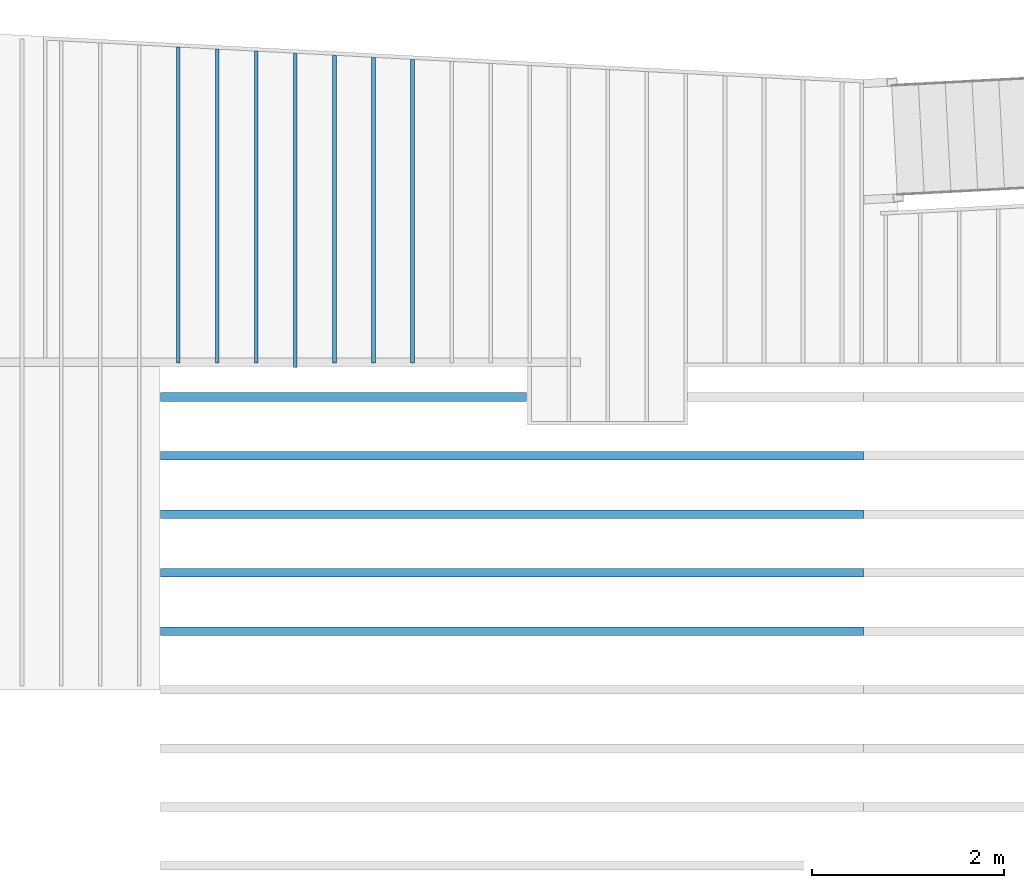
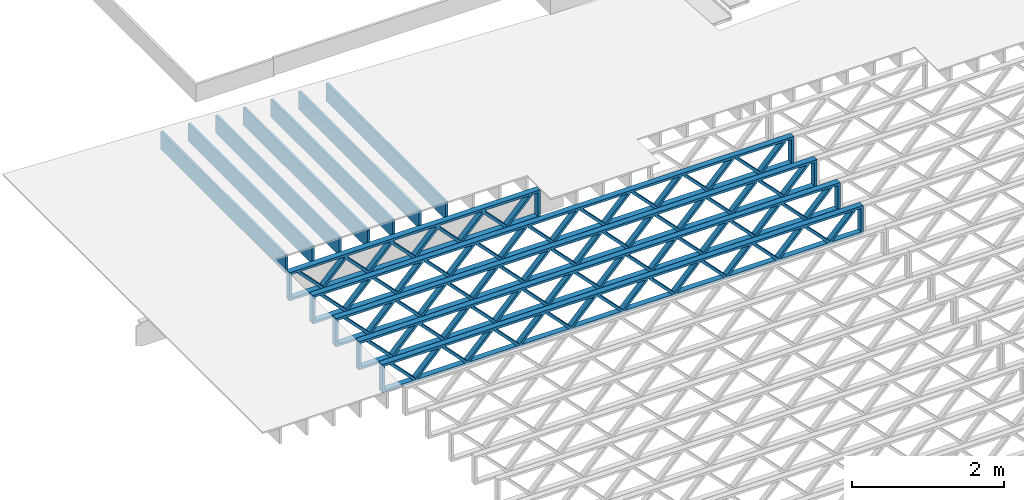
# One storey, part 3 of 23: 12 beams, 2 elements without a shape of their own.
"""IFC4 building model written with IfcOpenShell, lengths in feet."""

from ifc_helpers import new_model, entity, si_unit, converted_unit, derived_unit, direction, frame, frame_2d, origin, origin_2d_with_axis, place, context, subcontext, project, spatial, rectangle, extrude, source, transform, mapped, material, material_profile, profile_set, profile_usage, type_object, type_shapes, element, aggregate, save


model = new_model("IFC4")

# Units and contexts
model_context = context("Model", 3, precision=0.0001, world=origin(), true_north=direction((6.12303176911189e-17, 1.0)))
body_context = subcontext(model_context, "Body", "Model", "MODEL_VIEW")
ifc_project = project(units=[converted_unit("LENGTHUNIT", "FOOT", entity("IfcRatioMeasure", 0.3048), si_unit("LENGTHUNIT", "METRE"), dimensions=[1, 0, 0, 0, 0, 0, 0]), converted_unit("AREAUNIT", "SQUARE FOOT", entity("IfcRatioMeasure", 0.09290304), si_unit("AREAUNIT", "SQUARE_METRE"), dimensions=[2, 0, 0, 0, 0, 0, 0]), converted_unit("VOLUMEUNIT", "CUBIC FOOT", entity("IfcRatioMeasure", 0.028316846592), si_unit("VOLUMEUNIT", "CUBIC_METRE"), dimensions=[3, 0, 0, 0, 0, 0, 0]), converted_unit("PLANEANGLEUNIT", "DEGREE", entity("IfcRatioMeasure", 0.0174532925199433), si_unit("PLANEANGLEUNIT", "RADIAN"), dimensions=[0, 0, 0, 0, 0, 0, 0]), si_unit("MASSUNIT", "GRAM", prefix="KILO"), derived_unit("MASSDENSITYUNIT", [(si_unit("MASSUNIT", "GRAM", prefix="KILO"), 1), (si_unit("LENGTHUNIT", "METRE"), -3)]), derived_unit("MOMENTOFINERTIAUNIT", [(si_unit("LENGTHUNIT", "METRE"), 4)]), si_unit("TIMEUNIT", "SECOND"), si_unit("FREQUENCYUNIT", "HERTZ"), si_unit("THERMODYNAMICTEMPERATUREUNIT", "DEGREE_CELSIUS"), derived_unit("THERMALTRANSMITTANCEUNIT", [(si_unit("MASSUNIT", "GRAM", prefix="KILO"), 1), (si_unit("THERMODYNAMICTEMPERATUREUNIT", "KELVIN"), -1), (si_unit("TIMEUNIT", "SECOND"), -3)]), derived_unit("VOLUMETRICFLOWRATEUNIT", [(si_unit("LENGTHUNIT", "METRE"), 3), (si_unit("TIMEUNIT", "SECOND"), -1)]), si_unit("ELECTRICCURRENTUNIT", "AMPERE"), si_unit("ELECTRICVOLTAGEUNIT", "VOLT"), si_unit("POWERUNIT", "WATT"), si_unit("FORCEUNIT", "NEWTON"), si_unit("ILLUMINANCEUNIT", "LUX"), si_unit("LUMINOUSFLUXUNIT", "LUMEN"), si_unit("LUMINOUSINTENSITYUNIT", "CANDELA"), derived_unit("USERDEFINED", [(si_unit("MASSUNIT", "GRAM", prefix="KILO"), -1), (si_unit("LENGTHUNIT", "METRE"), -2), (si_unit("TIMEUNIT", "SECOND"), 3), (si_unit("LUMINOUSFLUXUNIT", "LUMEN"), 1)]), derived_unit("LINEARVELOCITYUNIT", [(si_unit("LENGTHUNIT", "METRE"), 1), (si_unit("TIMEUNIT", "SECOND"), -1)]), si_unit("PRESSUREUNIT", "PASCAL"), derived_unit("USERDEFINED", [(si_unit("LENGTHUNIT", "METRE"), -2), (si_unit("MASSUNIT", "GRAM", prefix="KILO"), 1), (si_unit("TIMEUNIT", "SECOND"), -2)]), derived_unit("LINEARFORCEUNIT", [(si_unit("MASSUNIT", "GRAM", prefix="KILO"), 1), (si_unit("LENGTHUNIT", "METRE"), 1), (si_unit("TIMEUNIT", "SECOND"), -2), (si_unit("LENGTHUNIT", "METRE"), -1)]), derived_unit("PLANARFORCEUNIT", [(si_unit("MASSUNIT", "GRAM", prefix="KILO"), 1), (si_unit("LENGTHUNIT", "METRE"), 1), (si_unit("TIMEUNIT", "SECOND"), -2), (si_unit("LENGTHUNIT", "METRE"), -2)])], contexts=[model_context])

# Site, building, storey
site_placement = place(None, origin())
site = spatial("IfcSite", under=ifc_project, at=site_placement, CompositionType="ELEMENT")
building_placement = place(site_placement, origin())
building = spatial("IfcBuilding", under=site, at=building_placement, CompositionType="ELEMENT")
storey_placement = place(building_placement, frame((0.0, 0.0, 10.8020833333333)))
storey = spatial("IfcBuildingStorey", under=building, at=storey_placement, Name="2ND FLOOR", CompositionType="ELEMENT", Elevation=10.8020833333333)

# Assembly, beams
assembly_1_placement = place(storey_placement, origin())
assembly_1 = element("IfcElementAssembly", 1, at=assembly_1_placement, inside=storey, Name="Structural Beam System:Structural Framing System", ObjectType="Structural Beam System:Structural Framing System", AssemblyPlace="NOTDEFINED", PredefinedType="BEAM_GRID")
ifc_material_1 = material(Name="WOOD TRUSS", Category="Materials")
ifc_material_profile_1 = material_profile(ifc_material_1, rectangle(XDim=1.73473973950632, YDim=0.125, at=frame_2d((-1.11022302462516e-16, 8.32667268468867e-17), x_axis=(1.0, 0.0))))
ifc_material_profile_2 = material_profile(ifc_material_1, rectangle(XDim=1.73473973950633, YDim=0.125, at=frame_2d((-1.11022302462516e-16, 8.32667268468867e-17), x_axis=(1.0, 0.0))))
ifc_material_profile_3 = material_profile(ifc_material_1, rectangle(XDim=1.73473973950632, YDim=0.125, at=frame_2d((-5.55111512312578e-17, 1.38777878078145e-16), x_axis=(1.0, 0.0))))
ifc_material_profile_4 = material_profile(ifc_material_1, rectangle(XDim=1.73473973950633, YDim=0.125, at=frame_2d((-1.11022302462516e-16, 8.32667268468867e-17), x_axis=(1.0, 0.0))))
ifc_material_profile_5 = material_profile(ifc_material_1, rectangle(XDim=1.73473973950632, YDim=0.125, at=frame_2d((-1.11022302462516e-16, 8.32667268468867e-17), x_axis=(1.0, 0.0))))
ifc_material_profile_6 = material_profile(ifc_material_1, rectangle(XDim=1.73473973950633, YDim=0.125, at=frame_2d((-2.77555756156289e-16, 3.05311331771918e-16), x_axis=(1.0, 0.0))))
ifc_material_profile_7 = material_profile(ifc_material_1, rectangle(XDim=1.73473973950632, YDim=0.124999999999999, at=frame_2d((-3.88578058618805e-16, -2.4980018054066e-16), x_axis=(1.0, 0.0))))
ifc_material_profile_8 = material_profile(ifc_material_1, rectangle(XDim=1.73473973950633, YDim=0.125, at=frame_2d((2.77555756156289e-16, -3.05311331771918e-16), x_axis=(1.0, 0.0))))
ifc_material_profile_9 = material_profile(ifc_material_1, rectangle(XDim=1.73473973950632, YDim=0.124999999999999, at=frame_2d((-1.11022302462516e-16, 8.32667268468867e-17), x_axis=(1.0, 0.0))))
ifc_material_profile_10 = material_profile(ifc_material_1, rectangle(XDim=1.73473973950633, YDim=0.125, at=origin_2d_with_axis()))
ifc_material_profile_11 = material_profile(ifc_material_1, rectangle(XDim=0.124999999999982, YDim=0.291666666666668, at=origin_2d_with_axis()))
ifc_material_profile_12 = material_profile(ifc_material_1, rectangle(XDim=0.124999999999932, YDim=0.291666666666664, at=origin_2d_with_axis()))
ifc_material_profile_13 = material_profile(ifc_material_1, rectangle(XDim=1.25000000000002, YDim=0.29166666666667, at=origin_2d_with_axis()))
ifc_material_profile_14 = material_profile(ifc_material_1, rectangle(XDim=1.25000000000004, YDim=0.291666666666667, at=origin_2d_with_axis()))
ifc_profile_set_1 = profile_set([ifc_material_profile_1, ifc_material_profile_2, ifc_material_profile_3, ifc_material_profile_4, ifc_material_profile_5, ifc_material_profile_6, ifc_material_profile_7, ifc_material_profile_8, ifc_material_profile_9, ifc_material_profile_10, ifc_material_profile_11, ifc_material_profile_12, ifc_material_profile_13, ifc_material_profile_14])
ifc_profile_usage_1 = profile_usage(ifc_profile_set_1, cardinal=8)
beam_type_1 = type_object("IfcBeamType", PredefinedType="BEAM", material=ifc_profile_set_1)
shared_shape_1 = source(origin(), body_context, "Body", "SweptSolid", [
    extrude(rectangle(XDim=1.73473973950632, YDim=0.125, at=frame_2d((-1.11022302462516e-16, 8.32667268468867e-17), x_axis=(1.0, 0.0))), frame((2.91681155651982, -0.145833333333334, 0.0), z_axis=(0.0, 1.0, 0.0), x_axis=(0.693383046997606, 0.0, 0.720569184836762)), (0.0, 0.0, 1.0), 0.291666666666667),
    extrude(rectangle(XDim=1.73473973950633, YDim=0.125, at=frame_2d((-1.11022302462516e-16, 8.32667268468867e-17), x_axis=(1.0, 0.0))), frame((1.66652568284655, -0.145833333333334, 0.0), z_axis=(0.0, 1.0, 0.0), x_axis=(0.69338304699761, 0.0, -0.720569184836758)), (0.0, 0.0, 1.0), 0.291666666666667),
    extrude(rectangle(XDim=1.73473973950632, YDim=0.125, at=frame_2d((-5.55111512312578e-17, 1.38777878078145e-16), x_axis=(1.0, 0.0))), frame((0.625142936836964, -0.145833333333334, 0.0), z_axis=(0.0, 1.0, 0.0), x_axis=(0.693383046997606, 0.0, 0.720569184836762)), (0.0, 0.0, 1.0), 0.291666666666667),
    extrude(rectangle(XDim=1.73473973950633, YDim=0.125, at=frame_2d((-1.11022302462516e-16, 8.32667268468867e-17), x_axis=(1.0, 0.0))), frame((-0.625142936836307, -0.145833333333334, 0.0), z_axis=(0.0, 1.0, 0.0), x_axis=(0.69338304699761, 0.0, -0.720569184836758)), (0.0, 0.0, 1.0), 0.291666666666667),
    extrude(rectangle(XDim=1.73473973950632, YDim=0.125, at=frame_2d((-1.11022302462516e-16, 8.32667268468867e-17), x_axis=(1.0, 0.0))), frame((-1.66652568284589, -0.145833333333334, 0.0), z_axis=(0.0, 1.0, 0.0), x_axis=(0.693383046997606, 0.0, 0.720569184836762)), (0.0, 0.0, 1.0), 0.291666666666667),
    extrude(rectangle(XDim=1.73473973950633, YDim=0.125, at=frame_2d((-2.77555756156289e-16, 3.05311331771918e-16), x_axis=(1.0, 0.0))), frame((-2.91681155651916, -0.145833333333334, 0.0), z_axis=(0.0, 1.0, 0.0), x_axis=(0.69338304699761, 0.0, -0.720569184836758)), (0.0, 0.0, 1.0), 0.291666666666667),
    extrude(rectangle(XDim=1.73473973950632, YDim=0.124999999999999, at=frame_2d((-3.88578058618805e-16, -2.4980018054066e-16), x_axis=(1.0, 0.0))), frame((5.20848017620267, -0.145833333333334, 0.0), z_axis=(0.0, 1.0, 0.0), x_axis=(0.693383046997607, 0.0, 0.720569184836761)), (0.0, 0.0, 1.0), 0.291666666666666),
    extrude(rectangle(XDim=1.73473973950633, YDim=0.125, at=frame_2d((2.77555756156289e-16, -3.05311331771918e-16), x_axis=(1.0, 0.0))), frame((3.9581943025294, -0.145833333333334, 0.0), z_axis=(0.0, 1.0, 0.0), x_axis=(0.69338304699761, 0.0, -0.720569184836758)), (0.0, 0.0, 1.0), 0.291666666666666),
    extrude(rectangle(XDim=1.73473973950632, YDim=0.124999999999999, at=frame_2d((-1.11022302462516e-16, 8.32667268468867e-17), x_axis=(1.0, 0.0))), frame((-3.95819430252874, -0.145833333333334, 0.0), z_axis=(0.0, 1.0, 0.0), x_axis=(0.693383046997606, 0.0, 0.720569184836762)), (0.0, 0.0, 1.0), 0.291666666666667),
    extrude(rectangle(XDim=1.73473973950633, YDim=0.125, at=origin_2d_with_axis()), frame((-5.20848017620202, -0.145833333333334, 0.0), z_axis=(0.0, 1.0, 0.0), x_axis=(0.69338304699761, 0.0, -0.720569184836758)), (0.0, 0.0, 1.0), 0.291666666666666),
    extrude(rectangle(XDim=0.124999999999982, YDim=0.291666666666668, at=origin_2d_with_axis()), frame((-6.25000390603229, 0.0, 0.687500000000054), z_axis=(1.0, 0.0, 0.0), x_axis=(0.0, 0.0, -1.0)), (0.0, 0.0, 1.0), 12.5000078120646),
    extrude(rectangle(XDim=0.124999999999932, YDim=0.291666666666664, at=origin_2d_with_axis()), frame((-6.25000390603208, 0.0, -0.687499999999984), z_axis=(1.0, 0.0, 0.0), x_axis=(0.0, 0.0, -1.0)), (0.0, 0.0, 1.0), 12.5000078120644),
    extrude(rectangle(XDim=1.25000000000002, YDim=0.29166666666667, at=origin_2d_with_axis()), frame((6.12500390603227, 0.0, 0.0), z_axis=(1.0, 0.0, 0.0), x_axis=(0.0, 0.0, -1.0)), (0.0, 0.0, 1.0), 0.12500000000002),
    extrude(rectangle(XDim=1.25000000000004, YDim=0.291666666666667, at=origin_2d_with_axis()), frame((-6.25000390603229, 0.0, 0.0), z_axis=(1.0, 0.0, 0.0), x_axis=(0.0, 0.0, -1.0)), (0.0, 0.0, 1.0), 0.125000000000023),
])
type_shapes(beam_type_1, [shared_shape_1])
beam_1_placement = place(assembly_1_placement, frame((-259.488164391561, 957.861934882651, -0.947916666657857)))
beam_1 = element("IfcBeam", 2, at=beam_1_placement, type_object=beam_type_1, material=ifc_profile_usage_1, PredefinedType="BEAM", context=body_context, shape_type="MappedRepresentation", body=[
    mapped(shared_shape_1, transform((0.0, 0.0, 0.0), scale=1.0)),
])
ifc_profile_usage_2 = profile_usage(ifc_profile_set_1, cardinal=8)
beam_type_2 = type_object("IfcBeamType", PredefinedType="BEAM", material=ifc_profile_set_1)
shared_shape_2 = source(origin(), body_context, "Body", "SweptSolid", [
    extrude(rectangle(XDim=1.73473973950632, YDim=0.124999999999999, at=frame_2d((5.55111512312578e-16, 7.21644966006352e-16), x_axis=(1.0, 0.0))), frame((8.37514585578398, -0.145833333333334, 0.0), z_axis=(0.0, 1.0, 0.0), x_axis=(0.693383046997606, 0.0, 0.720569184836762)), (0.0, 0.0, 1.0), 0.291666666666667),
    extrude(rectangle(XDim=1.73473973950633, YDim=0.125, at=origin_2d_with_axis()), frame((7.12485998211071, -0.145833333333334, 0.0), z_axis=(0.0, 1.0, 0.0), x_axis=(0.69338304699761, 0.0, -0.720569184836758)), (0.0, 0.0, 1.0), 0.291666666666666),
    extrude(rectangle(XDim=1.73473973950632, YDim=0.124999999999999, at=frame_2d((-1.11022302462516e-16, 8.32667268468867e-17), x_axis=(1.0, 0.0))), frame((5.79181154946831, -0.145833333333334, 0.0), z_axis=(0.0, 1.0, 0.0), x_axis=(0.693383046997606, 0.0, 0.720569184836762)), (0.0, 0.0, 1.0), 0.291666666666667),
    extrude(rectangle(XDim=1.73473973950633, YDim=0.125, at=origin_2d_with_axis()), frame((4.54152567579504, -0.145833333333334, 0.0), z_axis=(0.0, 1.0, 0.0), x_axis=(0.69338304699761, 0.0, -0.720569184836758)), (0.0, 0.0, 1.0), 0.291666666666666),
    extrude(rectangle(XDim=1.73473973950632, YDim=0.125, at=frame_2d((2.22044604925031e-16, 3.88578058618805e-16), x_axis=(1.0, 0.0))), frame((3.20847724315264, -0.145833333333334, 0.0), z_axis=(0.0, 1.0, 0.0), x_axis=(0.693383046997606, 0.0, 0.720569184836762)), (0.0, 0.0, 1.0), 0.291666666666667),
    extrude(rectangle(XDim=1.73473973950633, YDim=0.125, at=frame_2d((-1.11022302462516e-16, 8.32667268468867e-17), x_axis=(1.0, 0.0))), frame((1.95819136947937, -0.145833333333334, 0.0), z_axis=(0.0, 1.0, 0.0), x_axis=(0.69338304699761, 0.0, -0.720569184836758)), (0.0, 0.0, 1.0), 0.291666666666667),
    extrude(rectangle(XDim=1.73473973950632, YDim=0.125, at=frame_2d((-5.55111512312578e-17, 1.38777878078145e-16), x_axis=(1.0, 0.0))), frame((0.625142936836964, -0.145833333333334, 0.0), z_axis=(0.0, 1.0, 0.0), x_axis=(0.693383046997606, 0.0, 0.720569184836762)), (0.0, 0.0, 1.0), 0.291666666666667),
    extrude(rectangle(XDim=1.73473973950633, YDim=0.125, at=frame_2d((-1.11022302462516e-16, 8.32667268468867e-17), x_axis=(1.0, 0.0))), frame((-0.625142936836306, -0.145833333333334, 0.0), z_axis=(0.0, 1.0, 0.0), x_axis=(0.69338304699761, 0.0, -0.720569184836758)), (0.0, 0.0, 1.0), 0.291666666666667),
    extrude(rectangle(XDim=1.73473973950632, YDim=0.125, at=frame_2d((-1.11022302462516e-16, 8.32667268468867e-17), x_axis=(1.0, 0.0))), frame((-1.95819136947871, -0.145833333333334, 0.0), z_axis=(0.0, 1.0, 0.0), x_axis=(0.693383046997606, 0.0, 0.720569184836762)), (0.0, 0.0, 1.0), 0.291666666666667),
    extrude(rectangle(XDim=1.73473973950633, YDim=0.125, at=origin_2d_with_axis()), frame((-3.20847724315198, -0.145833333333334, 0.0), z_axis=(0.0, 1.0, 0.0), x_axis=(0.69338304699761, 0.0, -0.720569184836758)), (0.0, 0.0, 1.0), 0.291666666666667),
    extrude(rectangle(XDim=1.73473973950632, YDim=0.124999999999999, at=frame_2d((-1.11022302462516e-16, 8.32667268468867e-17), x_axis=(1.0, 0.0))), frame((-4.54152567579438, -0.145833333333334, 0.0), z_axis=(0.0, 1.0, 0.0), x_axis=(0.693383046997606, 0.0, 0.720569184836762)), (0.0, 0.0, 1.0), 0.291666666666667),
    extrude(rectangle(XDim=1.73473973950633, YDim=0.125, at=origin_2d_with_axis()), frame((-5.79181154946765, -0.145833333333334, 0.0), z_axis=(0.0, 1.0, 0.0), x_axis=(0.69338304699761, 0.0, -0.720569184836758)), (0.0, 0.0, 1.0), 0.291666666666666),
    extrude(rectangle(XDim=1.73473973950632, YDim=0.124999999999999, at=frame_2d((-1.11022302462516e-16, 8.32667268468867e-17), x_axis=(1.0, 0.0))), frame((-7.12485998211005, -0.145833333333334, 0.0), z_axis=(0.0, 1.0, 0.0), x_axis=(0.693383046997606, 0.0, 0.720569184836762)), (0.0, 0.0, 1.0), 0.291666666666667),
    extrude(rectangle(XDim=1.73473973950633, YDim=0.125, at=frame_2d((-2.77555756156289e-16, 3.05311331771918e-16), x_axis=(1.0, 0.0))), frame((-8.37514585578332, -0.145833333333334, 0.0), z_axis=(0.0, 1.0, 0.0), x_axis=(0.69338304699761, 0.0, -0.720569184836758)), (0.0, 0.0, 1.0), 0.291666666666666),
    extrude(rectangle(XDim=1.73473973950632, YDim=0.125, at=frame_2d((-7.21644966006352e-16, -5.55111512312578e-16), x_axis=(1.0, 0.0))), frame((10.9584801620997, -0.145833333333334, 0.0), z_axis=(0.0, 1.0, 0.0), x_axis=(0.693383046997606, 0.0, 0.720569184836762)), (0.0, 0.0, 1.0), 0.291666666666667),
    extrude(rectangle(XDim=1.73473973950633, YDim=0.125, at=origin_2d_with_axis()), frame((9.70819428842638, -0.145833333333334, 0.0), z_axis=(0.0, 1.0, 0.0), x_axis=(0.69338304699761, 0.0, -0.720569184836758)), (0.0, 0.0, 1.0), 0.291666666666666),
    extrude(rectangle(XDim=1.73473973950632, YDim=0.125, at=frame_2d((-5.55111512312578e-17, 8.32667268468867e-17), x_axis=(1.0, 0.0))), frame((-9.70819428842572, -0.145833333333334, 0.0), z_axis=(0.0, 1.0, 0.0), x_axis=(0.693383046997606, 0.0, 0.720569184836762)), (0.0, 0.0, 1.0), 0.291666666666667),
    extrude(rectangle(XDim=1.73473973950633, YDim=0.125, at=origin_2d_with_axis()), frame((-10.958480162099, -0.145833333333334, 0.0), z_axis=(0.0, 1.0, 0.0), x_axis=(0.69338304699761, 0.0, -0.720569184836758)), (0.0, 0.0, 1.0), 0.291666666666666),
    extrude(rectangle(XDim=0.124999999999982, YDim=0.291666666666668, at=origin_2d_with_axis()), frame((-12.0000038919293, 0.0, 0.687500000000054), z_axis=(1.0, 0.0, 0.0), x_axis=(0.0, 0.0, -1.0)), (0.0, 0.0, 1.0), 24.0000077838585),
    extrude(rectangle(XDim=0.124999999999932, YDim=0.291666666666664, at=origin_2d_with_axis()), frame((-12.0000038919291, 0.0, -0.687499999999984), z_axis=(1.0, 0.0, 0.0), x_axis=(0.0, 0.0, -1.0)), (0.0, 0.0, 1.0), 24.0000077838583),
    extrude(rectangle(XDim=1.25000000000002, YDim=0.29166666666667, at=origin_2d_with_axis()), frame((11.8750038919292, 0.0, 0.0), z_axis=(1.0, 0.0, 0.0), x_axis=(0.0, 0.0, -1.0)), (0.0, 0.0, 1.0), 0.12500000000002),
    extrude(rectangle(XDim=1.25000000000004, YDim=0.291666666666667, at=origin_2d_with_axis()), frame((-12.0000038919293, 0.0, 0.0), z_axis=(1.0, 0.0, 0.0), x_axis=(0.0, 0.0, -1.0)), (0.0, 0.0, 1.0), 0.125000000000023),
])
type_shapes(beam_type_2, [shared_shape_2])
beam_2_placement = place(assembly_1_placement, frame((-253.738164405664, 955.861934882651, -0.947916666657859)))
beam_2 = element("IfcBeam", 3, at=beam_2_placement, type_object=beam_type_2, material=ifc_profile_usage_2, PredefinedType="BEAM", context=body_context, shape_type="MappedRepresentation", body=[
    mapped(shared_shape_2, transform((0.0, 0.0, 0.0), scale=1.0)),
])
ifc_profile_usage_3 = profile_usage(ifc_profile_set_1, cardinal=8)
beam_type_3 = type_object("IfcBeamType", PredefinedType="BEAM", material=ifc_profile_set_1)
shared_shape_3 = source(origin(), body_context, "Body", "SweptSolid", [
    extrude(rectangle(XDim=1.73473973950632, YDim=0.124999999999999, at=frame_2d((5.55111512312578e-16, 7.21644966006352e-16), x_axis=(1.0, 0.0))), frame((8.37514585578398, -0.145833333333334, 0.0), z_axis=(0.0, 1.0, 0.0), x_axis=(0.693383046997606, 0.0, 0.720569184836762)), (0.0, 0.0, 1.0), 0.291666666666667),
    extrude(rectangle(XDim=1.73473973950633, YDim=0.125, at=origin_2d_with_axis()), frame((7.12485998211071, -0.145833333333334, 0.0), z_axis=(0.0, 1.0, 0.0), x_axis=(0.69338304699761, 0.0, -0.720569184836758)), (0.0, 0.0, 1.0), 0.291666666666666),
    extrude(rectangle(XDim=1.73473973950632, YDim=0.124999999999999, at=frame_2d((-1.11022302462516e-16, 8.32667268468867e-17), x_axis=(1.0, 0.0))), frame((5.79181154946831, -0.145833333333334, 0.0), z_axis=(0.0, 1.0, 0.0), x_axis=(0.693383046997606, 0.0, 0.720569184836762)), (0.0, 0.0, 1.0), 0.291666666666667),
    extrude(rectangle(XDim=1.73473973950633, YDim=0.125, at=origin_2d_with_axis()), frame((4.54152567579504, -0.145833333333334, 0.0), z_axis=(0.0, 1.0, 0.0), x_axis=(0.69338304699761, 0.0, -0.720569184836758)), (0.0, 0.0, 1.0), 0.291666666666666),
    extrude(rectangle(XDim=1.73473973950632, YDim=0.125, at=frame_2d((2.22044604925031e-16, 3.88578058618805e-16), x_axis=(1.0, 0.0))), frame((3.20847724315264, -0.145833333333334, 0.0), z_axis=(0.0, 1.0, 0.0), x_axis=(0.693383046997606, 0.0, 0.720569184836762)), (0.0, 0.0, 1.0), 0.291666666666667),
    extrude(rectangle(XDim=1.73473973950633, YDim=0.125, at=frame_2d((-1.11022302462516e-16, 8.32667268468867e-17), x_axis=(1.0, 0.0))), frame((1.95819136947937, -0.145833333333334, 0.0), z_axis=(0.0, 1.0, 0.0), x_axis=(0.69338304699761, 0.0, -0.720569184836758)), (0.0, 0.0, 1.0), 0.291666666666667),
    extrude(rectangle(XDim=1.73473973950632, YDim=0.125, at=frame_2d((-5.55111512312578e-17, 1.38777878078145e-16), x_axis=(1.0, 0.0))), frame((0.625142936836964, -0.145833333333334, 0.0), z_axis=(0.0, 1.0, 0.0), x_axis=(0.693383046997606, 0.0, 0.720569184836762)), (0.0, 0.0, 1.0), 0.291666666666667),
    extrude(rectangle(XDim=1.73473973950633, YDim=0.125, at=frame_2d((-1.11022302462516e-16, 8.32667268468867e-17), x_axis=(1.0, 0.0))), frame((-0.625142936836306, -0.145833333333334, 0.0), z_axis=(0.0, 1.0, 0.0), x_axis=(0.69338304699761, 0.0, -0.720569184836758)), (0.0, 0.0, 1.0), 0.291666666666667),
    extrude(rectangle(XDim=1.73473973950632, YDim=0.125, at=frame_2d((-1.11022302462516e-16, 8.32667268468867e-17), x_axis=(1.0, 0.0))), frame((-1.95819136947871, -0.145833333333334, 0.0), z_axis=(0.0, 1.0, 0.0), x_axis=(0.693383046997606, 0.0, 0.720569184836762)), (0.0, 0.0, 1.0), 0.291666666666667),
    extrude(rectangle(XDim=1.73473973950633, YDim=0.125, at=origin_2d_with_axis()), frame((-3.20847724315198, -0.145833333333334, 0.0), z_axis=(0.0, 1.0, 0.0), x_axis=(0.69338304699761, 0.0, -0.720569184836758)), (0.0, 0.0, 1.0), 0.291666666666667),
    extrude(rectangle(XDim=1.73473973950632, YDim=0.124999999999999, at=frame_2d((-1.11022302462516e-16, 8.32667268468867e-17), x_axis=(1.0, 0.0))), frame((-4.54152567579438, -0.145833333333334, 0.0), z_axis=(0.0, 1.0, 0.0), x_axis=(0.693383046997606, 0.0, 0.720569184836762)), (0.0, 0.0, 1.0), 0.291666666666667),
    extrude(rectangle(XDim=1.73473973950633, YDim=0.125, at=origin_2d_with_axis()), frame((-5.79181154946765, -0.145833333333334, 0.0), z_axis=(0.0, 1.0, 0.0), x_axis=(0.69338304699761, 0.0, -0.720569184836758)), (0.0, 0.0, 1.0), 0.291666666666666),
    extrude(rectangle(XDim=1.73473973950632, YDim=0.124999999999999, at=frame_2d((-1.11022302462516e-16, 8.32667268468867e-17), x_axis=(1.0, 0.0))), frame((-7.12485998211005, -0.145833333333334, 0.0), z_axis=(0.0, 1.0, 0.0), x_axis=(0.693383046997606, 0.0, 0.720569184836762)), (0.0, 0.0, 1.0), 0.291666666666667),
    extrude(rectangle(XDim=1.73473973950633, YDim=0.125, at=frame_2d((-2.77555756156289e-16, 3.05311331771918e-16), x_axis=(1.0, 0.0))), frame((-8.37514585578332, -0.145833333333334, 0.0), z_axis=(0.0, 1.0, 0.0), x_axis=(0.69338304699761, 0.0, -0.720569184836758)), (0.0, 0.0, 1.0), 0.291666666666666),
    extrude(rectangle(XDim=1.73473973950632, YDim=0.125, at=frame_2d((-7.21644966006352e-16, -5.55111512312578e-16), x_axis=(1.0, 0.0))), frame((10.9584801620997, -0.145833333333334, 0.0), z_axis=(0.0, 1.0, 0.0), x_axis=(0.693383046997606, 0.0, 0.720569184836762)), (0.0, 0.0, 1.0), 0.291666666666667),
    extrude(rectangle(XDim=1.73473973950633, YDim=0.125, at=origin_2d_with_axis()), frame((9.70819428842638, -0.145833333333334, 0.0), z_axis=(0.0, 1.0, 0.0), x_axis=(0.69338304699761, 0.0, -0.720569184836758)), (0.0, 0.0, 1.0), 0.291666666666666),
    extrude(rectangle(XDim=1.73473973950632, YDim=0.125, at=frame_2d((-5.55111512312578e-17, 8.32667268468867e-17), x_axis=(1.0, 0.0))), frame((-9.70819428842572, -0.145833333333334, 0.0), z_axis=(0.0, 1.0, 0.0), x_axis=(0.693383046997606, 0.0, 0.720569184836762)), (0.0, 0.0, 1.0), 0.291666666666667),
    extrude(rectangle(XDim=1.73473973950633, YDim=0.125, at=origin_2d_with_axis()), frame((-10.958480162099, -0.145833333333334, 0.0), z_axis=(0.0, 1.0, 0.0), x_axis=(0.69338304699761, 0.0, -0.720569184836758)), (0.0, 0.0, 1.0), 0.291666666666666),
    extrude(rectangle(XDim=0.124999999999982, YDim=0.291666666666668, at=origin_2d_with_axis()), frame((-12.0000038919293, 0.0, 0.687500000000054), z_axis=(1.0, 0.0, 0.0), x_axis=(0.0, 0.0, -1.0)), (0.0, 0.0, 1.0), 24.0000077838585),
    extrude(rectangle(XDim=0.124999999999932, YDim=0.291666666666664, at=origin_2d_with_axis()), frame((-12.0000038919291, 0.0, -0.687499999999984), z_axis=(1.0, 0.0, 0.0), x_axis=(0.0, 0.0, -1.0)), (0.0, 0.0, 1.0), 24.0000077838583),
    extrude(rectangle(XDim=1.25000000000002, YDim=0.29166666666667, at=origin_2d_with_axis()), frame((11.8750038919292, 0.0, 0.0), z_axis=(1.0, 0.0, 0.0), x_axis=(0.0, 0.0, -1.0)), (0.0, 0.0, 1.0), 0.12500000000002),
    extrude(rectangle(XDim=1.25000000000004, YDim=0.291666666666667, at=origin_2d_with_axis()), frame((-12.0000038919293, 0.0, 0.0), z_axis=(1.0, 0.0, 0.0), x_axis=(0.0, 0.0, -1.0)), (0.0, 0.0, 1.0), 0.125000000000023),
])
type_shapes(beam_type_3, [shared_shape_3])
beam_3_placement = place(assembly_1_placement, frame((-253.738164405664, 953.861934882651, -0.947916666657859)))
beam_3 = element("IfcBeam", 4, at=beam_3_placement, type_object=beam_type_3, material=ifc_profile_usage_3, PredefinedType="BEAM", context=body_context, shape_type="MappedRepresentation", body=[
    mapped(shared_shape_3, transform((0.0, 0.0, 0.0), scale=1.0)),
])
ifc_profile_usage_4 = profile_usage(ifc_profile_set_1, cardinal=8)
beam_4_placement = place(assembly_1_placement, frame((-253.738164405664, 951.861934882651, -0.947916666657859)))
beam_4 = element("IfcBeam", 5, at=beam_4_placement, type_object=beam_type_3, material=ifc_profile_usage_4, PredefinedType="BEAM", context=body_context, shape_type="MappedRepresentation", body=[
    mapped(shared_shape_3, transform((0.0, 0.0, 0.0), scale=1.0)),
])
ifc_profile_usage_5 = profile_usage(ifc_profile_set_1, cardinal=8)
beam_5_placement = place(assembly_1_placement, frame((-253.738164405664, 949.861934882651, -0.947916666657859)))
beam_5 = element("IfcBeam", 6, at=beam_5_placement, type_object=beam_type_3, material=ifc_profile_usage_5, PredefinedType="BEAM", context=body_context, shape_type="MappedRepresentation", body=[
    mapped(shared_shape_3, transform((0.0, 0.0, 0.0), scale=1.0)),
])
aggregate(assembly_1, [beam_1, beam_2, beam_3, beam_4, beam_5])

assembly_2_placement = place(storey_placement, origin())
assembly_2 = element("IfcElementAssembly", 7, at=assembly_2_placement, inside=storey, Name="Structural Beam System:Structural Framing System", ObjectType="Structural Beam System:Structural Framing System", AssemblyPlace="NOTDEFINED", PredefinedType="BEAM_GRID")
ifc_material_2 = material(Category="Materials")
ifc_material_profile_15 = material_profile(ifc_material_2, rectangle(XDim=0.9375, YDim=0.125000000000011, at=origin_2d_with_axis()))
ifc_profile_set_2 = profile_set([ifc_material_profile_15])
ifc_profile_usage_6 = profile_usage(ifc_profile_set_2, cardinal=8)
beam_type_4 = type_object("IfcBeamType", PredefinedType="BEAM", material=ifc_profile_set_2)
shared_shape_4 = source(origin(), body_context, "Body", "SweptSolid", [
    extrude(rectangle(XDim=0.9375, YDim=0.125000000000011, at=origin_2d_with_axis()), frame((-5.39038281320103, 0.0, 0.0), z_axis=(1.0, 0.0, 0.0), x_axis=(0.0, 0.0, -1.0)), (0.0, 0.0, 1.0), 10.7807656264021),
])
type_shapes(beam_type_4, [shared_shape_4])
beam_6_placement = place(assembly_2_placement, frame((-265.133993818795, 964.418986982867, -0.729166666666744), z_axis=(0.0, 0.0, 1.0), x_axis=(0.0, 1.0, 0.0)))
beam_6 = element("IfcBeam", 8, at=beam_6_placement, type_object=beam_type_4, material=ifc_profile_usage_6, PredefinedType="BEAM", context=body_context, shape_type="MappedRepresentation", body=[
    mapped(shared_shape_4, transform((0.0, 0.0, 0.0), scale=1.0)),
])
ifc_profile_usage_7 = profile_usage(ifc_profile_set_2, cardinal=8)
beam_type_5 = type_object("IfcBeamType", PredefinedType="BEAM", material=ifc_profile_set_2)
shared_shape_5 = source(origin(), body_context, "Body", "SweptSolid", [
    extrude(rectangle(XDim=0.9375, YDim=0.125000000000011, at=origin_2d_with_axis()), frame((-5.355444293679, 0.0, 0.0), z_axis=(1.0, 0.0, 0.0), x_axis=(0.0, 0.0, -1.0)), (0.0, 0.0, 1.0), 10.710888587358),
])
type_shapes(beam_type_5, [shared_shape_5])
beam_7_placement = place(assembly_2_placement, frame((-263.800660485462, 964.384048463345, -0.729166666666744), z_axis=(0.0, 0.0, 1.0), x_axis=(0.0, 1.0, 0.0)))
beam_7 = element("IfcBeam", 9, at=beam_7_placement, type_object=beam_type_5, material=ifc_profile_usage_7, PredefinedType="BEAM", context=body_context, shape_type="MappedRepresentation", body=[
    mapped(shared_shape_5, transform((0.0, 0.0, 0.0), scale=1.0)),
])
ifc_profile_usage_8 = profile_usage(ifc_profile_set_2, cardinal=8)
beam_type_6 = type_object("IfcBeamType", PredefinedType="BEAM", material=ifc_profile_set_2)
shared_shape_6 = source(origin(), body_context, "Body", "SweptSolid", [
    extrude(rectangle(XDim=0.9375, YDim=0.125000000000011, at=origin_2d_with_axis()), frame((-5.32050577415703, 0.0, 0.0), z_axis=(1.0, 0.0, 0.0), x_axis=(0.0, 0.0, -1.0)), (0.0, 0.0, 1.0), 10.6410115483141),
])
type_shapes(beam_type_6, [shared_shape_6])
beam_8_placement = place(assembly_2_placement, frame((-262.467327152129, 964.349109943823, -0.729166666666744), z_axis=(0.0, 0.0, 1.0), x_axis=(0.0, 1.0, 0.0)))
beam_8 = element("IfcBeam", 10, at=beam_8_placement, type_object=beam_type_6, material=ifc_profile_usage_8, PredefinedType="BEAM", context=body_context, shape_type="MappedRepresentation", body=[
    mapped(shared_shape_6, transform((0.0, 0.0, 0.0), scale=1.0)),
])
ifc_profile_usage_9 = profile_usage(ifc_profile_set_2, cardinal=8)
beam_type_7 = type_object("IfcBeamType", PredefinedType="BEAM", material=ifc_profile_set_2)
shared_shape_7 = source(origin(), body_context, "Body", "SweptSolid", [
    extrude(rectangle(XDim=0.9375, YDim=0.125000000000011, at=origin_2d_with_axis()), frame((-5.25431782024765, 0.0, 0.0), z_axis=(1.0, 0.0, 0.0), x_axis=(0.0, 0.0, -1.0)), (0.0, 0.0, 1.0), 10.7378023029744),
])
type_shapes(beam_type_7, [shared_shape_7])
beam_9_placement = place(assembly_2_placement, frame((-261.133993818795, 964.116254196209, -0.729166666666744), z_axis=(0.0, 0.0, 1.0), x_axis=(0.0, 1.0, 0.0)))
beam_9 = element("IfcBeam", 11, at=beam_9_placement, type_object=beam_type_7, material=ifc_profile_usage_9, PredefinedType="BEAM", context=body_context, shape_type="MappedRepresentation", body=[
    mapped(shared_shape_7, transform((0.0, 0.0, 0.0), scale=1.0)),
])
ifc_profile_usage_10 = profile_usage(ifc_profile_set_2, cardinal=8)
beam_type_8 = type_object("IfcBeamType", PredefinedType="BEAM", material=ifc_profile_set_2)
shared_shape_8 = source(origin(), body_context, "Body", "SweptSolid", [
    extrude(rectangle(XDim=0.9375, YDim=0.125000000000011, at=origin_2d_with_axis()), frame((-5.25062873511297, 0.0, 0.0), z_axis=(1.0, 0.0, 0.0), x_axis=(0.0, 0.0, -1.0)), (0.0, 0.0, 1.0), 10.5012574702259),
])
type_shapes(beam_type_8, [shared_shape_8])
beam_10_placement = place(assembly_2_placement, frame((-259.800660485462, 964.279232904779, -0.729166666666744), z_axis=(0.0, 0.0, 1.0), x_axis=(0.0, 1.0, 0.0)))
beam_10 = element("IfcBeam", 12, at=beam_10_placement, type_object=beam_type_8, material=ifc_profile_usage_10, PredefinedType="BEAM", context=body_context, shape_type="MappedRepresentation", body=[
    mapped(shared_shape_8, transform((0.0, 0.0, 0.0), scale=1.0)),
])
ifc_profile_usage_11 = profile_usage(ifc_profile_set_2, cardinal=8)
beam_type_9 = type_object("IfcBeamType", PredefinedType="BEAM", material=ifc_profile_set_2)
shared_shape_9 = source(origin(), body_context, "Body", "SweptSolid", [
    extrude(rectangle(XDim=0.9375, YDim=0.125000000000011, at=origin_2d_with_axis()), frame((-5.21569021559094, 0.0, 0.0), z_axis=(1.0, 0.0, 0.0), x_axis=(0.0, 0.0, -1.0)), (0.0, 0.0, 1.0), 10.4313804311819),
])
type_shapes(beam_type_9, [shared_shape_9])
beam_11_placement = place(assembly_2_placement, frame((-258.467327152129, 964.244294385257, -0.729166666666744), z_axis=(0.0, 0.0, 1.0), x_axis=(0.0, 1.0, 0.0)))
beam_11 = element("IfcBeam", 13, at=beam_11_placement, type_object=beam_type_9, material=ifc_profile_usage_11, PredefinedType="BEAM", context=body_context, shape_type="MappedRepresentation", body=[
    mapped(shared_shape_9, transform((0.0, 0.0, 0.0), scale=1.0)),
])
ifc_profile_usage_12 = profile_usage(ifc_profile_set_2, cardinal=8)
beam_type_10 = type_object("IfcBeamType", PredefinedType="BEAM", material=ifc_profile_set_2)
shared_shape_10 = source(origin(), body_context, "Body", "SweptSolid", [
    extrude(rectangle(XDim=0.9375, YDim=0.125000000000011, at=origin_2d_with_axis()), frame((-5.18075169606897, 0.0, 0.0), z_axis=(1.0, 0.0, 0.0), x_axis=(0.0, 0.0, -1.0)), (0.0, 0.0, 1.0), 10.3615033921379),
])
type_shapes(beam_type_10, [shared_shape_10])
beam_12_placement = place(assembly_2_placement, frame((-257.133993818795, 964.209355865735, -0.729166666666744), z_axis=(0.0, 0.0, 1.0), x_axis=(0.0, 1.0, 0.0)))
beam_12 = element("IfcBeam", 14, at=beam_12_placement, type_object=beam_type_10, material=ifc_profile_usage_12, PredefinedType="BEAM", context=body_context, shape_type="MappedRepresentation", body=[
    mapped(shared_shape_10, transform((0.0, 0.0, 0.0), scale=1.0)),
])
aggregate(assembly_2, [beam_6, beam_7, beam_8, beam_9, beam_10, beam_11, beam_12])

save(model, "model.ifc")
